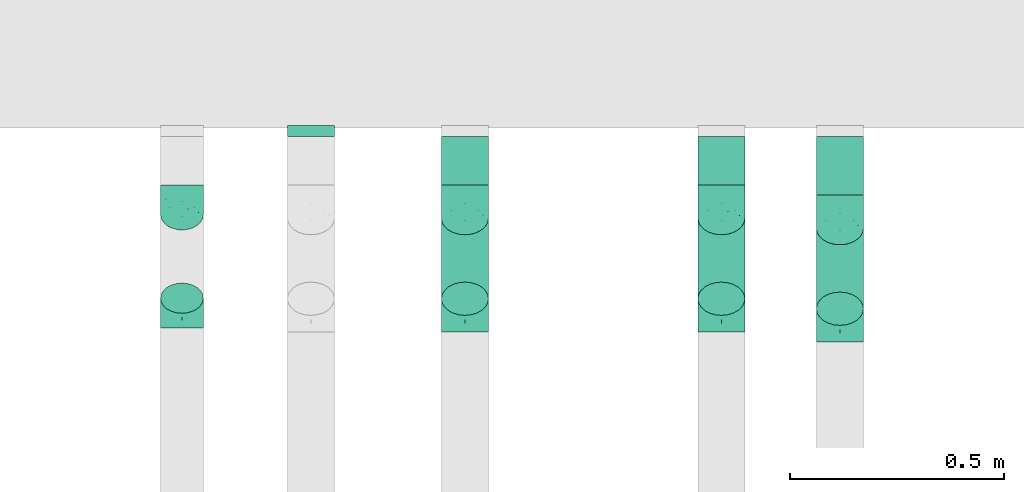
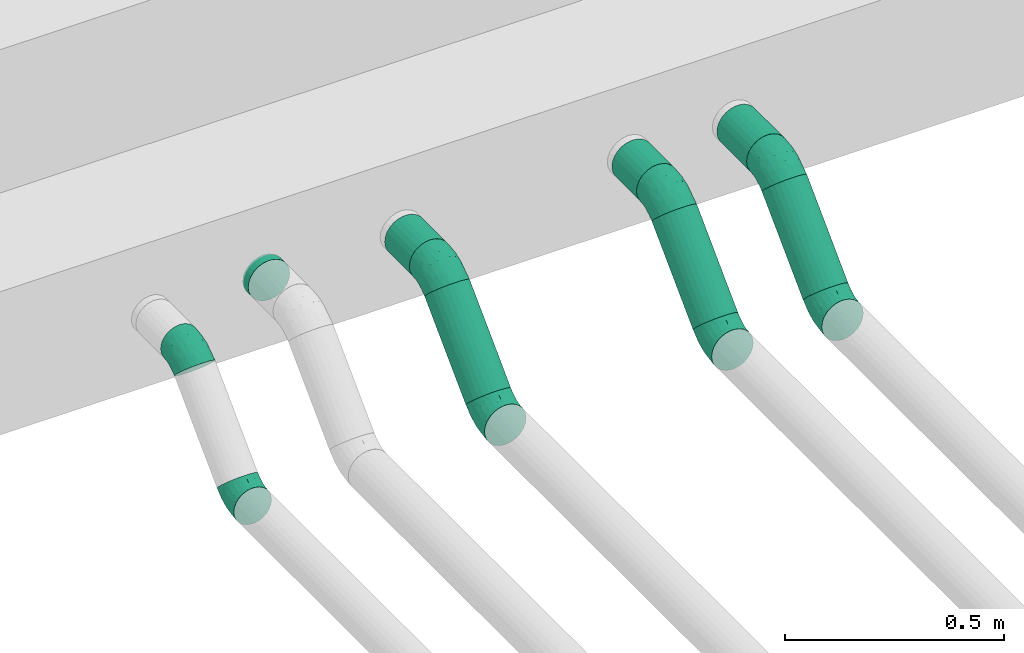
# One storey, part 21 of 91: 9 flow fittings, 6 flow segments.
"""IFC2X3 building model written with IfcOpenShell, lengths in millimetres."""

from ifc_helpers import new_model, entity, si_unit, converted_unit, derived_unit, direction, frame, origin_with_axes, origin_2d_with_axis, place, context, subcontext, project, spatial, hollow_circle, extrude, open_shell, surface_model, source, transform, mapped, material, layer, layer_set, layer_usage, type_object, element, save


model = new_model("IFC2X3")

# Units and contexts
model_context = context("Model", 3, precision=1e-05, world=origin_with_axes(), true_north=direction((0.0, 1.0)))
body_context = subcontext(model_context, "Body", "Model", "MODEL_VIEW")
ifc_project = project(units=[si_unit("AREAUNIT", "SQUARE_METRE"), si_unit("VOLUMEUNIT", "CUBIC_METRE", prefix="DECI"), si_unit("TIMEUNIT", "SECOND"), si_unit("THERMODYNAMICTEMPERATUREUNIT", "DEGREE_CELSIUS"), si_unit("PRESSUREUNIT", "PASCAL"), si_unit("MASSUNIT", "GRAM", prefix="KILO"), si_unit("LENGTHUNIT", "METRE", prefix="MILLI"), si_unit("POWERUNIT", "WATT"), si_unit("ELECTRICCURRENTUNIT", "AMPERE"), si_unit("ELECTRICVOLTAGEUNIT", "VOLT"), derived_unit("VOLUMETRICFLOWRATEUNIT", [(si_unit("VOLUMEUNIT", "CUBIC_METRE", prefix="DECI"), 1), (si_unit("TIMEUNIT", "SECOND"), -1)]), derived_unit("LINEARVELOCITYUNIT", [(si_unit("LENGTHUNIT", "METRE"), 1), (si_unit("TIMEUNIT", "SECOND"), -1)]), derived_unit("MASSDENSITYUNIT", [(si_unit("MASSUNIT", "GRAM", prefix="KILO"), 1), (si_unit("VOLUMEUNIT", "CUBIC_METRE"), -1)]), converted_unit("PLANEANGLEUNIT", "DEGREE", entity("IfcRatioMeasure", 0.01745), si_unit("PLANEANGLEUNIT", "RADIAN"), dimensions=[0, 0, 0, 0, 0, 0, 0])], contexts=[model_context])

# Site, building, storey
site_placement = place(None, origin_with_axes())
site = spatial("IfcSite", under=ifc_project, at=site_placement, CompositionType="ELEMENT")
building_placement = place(site_placement, origin_with_axes())
building = spatial("IfcBuilding", under=site, at=building_placement, Name="mc-building", CompositionType="ELEMENT")
storey_placement = place(building_placement, frame((0.0, 0.0, 8700.0), z_axis=(0.0, 0.0, 1.0), x_axis=(1.0, 0.0, 0.0)))
storey = spatial("IfcBuildingStorey", under=building, at=storey_placement, CompositionType="ELEMENT", Elevation=8700.0)

# Flow segments
ifc_material = material(Name="FZ1")
ifc_layer = layer(ifc_material, 0.0)
ifc_layer_set = layer_set([ifc_layer], Name="FZ1")
ifc_layer_usage = layer_usage(ifc_layer_set, "AXIS1", "POSITIVE", 0.0)
duct_segment_type = type_object("IfcDuctSegmentType", PredefinedType="RIGIDSEGMENT")
shared_shape_1 = source(origin_with_axes(), body_context, "Body", "SweptSolid", [
    extrude(hollow_circle(Radius=55.0, WallThickness=2.0, at=origin_2d_with_axis()), frame((0.0, 0.0, 0.0), z_axis=(1.0, 0.0, 0.0), x_axis=(0.0, 1.0, 0.0)), (0.0, 0.0, 1.0), 266.7),
])
for number, where, z_axis, x_axis in (
    (1, (12930.40917, 2717.07815, 635.78175), (0.0, -0.707107, 0.707107), (0.0, -0.707107, -0.707107)),
    (2, (12653.05388, 2740.42338, 635.78175), (0.0, -0.707107, 0.707107), (0.0, -0.707107, -0.707107)),
    (3, (12053.05418, 2740.42338, 635.78175), (0.0, -0.707107, 0.707107), (0.0, -0.707107, -0.707107)),
):
    element("IfcFlowSegment", number, at=place(storey_placement, frame(where, z_axis=z_axis, x_axis=x_axis)), inside=storey, type_object=duct_segment_type, material=ifc_layer_usage, context=body_context, shape_type="MappedRepresentation", body=[
        mapped(shared_shape_1, transform((0.0, 0.0, 0.0), scale=1.0)),
    ])
shared_shape_2 = source(origin_with_axes(), body_context, "Body", "SweptSolid", [
    extrude(hollow_circle(Radius=55.0, WallThickness=2.0, at=origin_2d_with_axis()), frame((0.0, 0.0, 0.0), z_axis=(1.0, 0.0, 0.0), x_axis=(0.0, 1.0, 0.0)), (0.0, 0.0, 1.0), 136.3),
])
flow_segment_placement = place(storey_placement, frame((12930.40917, 2931.20513, 668.0), z_axis=(0.0, 0.0, 1.0), x_axis=(0.0, -1.0, 0.0)))
element("IfcFlowSegment", 4, at=flow_segment_placement, inside=storey, type_object=duct_segment_type, material=ifc_layer_usage, context=body_context, shape_type="MappedRepresentation", body=[
    mapped(shared_shape_2, transform((0.0, 0.0, 0.0), scale=1.0)),
])

# Flow fittings
duct_fitting_type_1 = type_object("IfcDuctFittingType", Name="BU", PredefinedType="BEND")
shared_shape_3 = source(origin_with_axes(), body_context, "Body", "SurfaceModel", [
    surface_model("IfcShellBasedSurfaceModel", [(-45.56349, 0.0, -55.0), (-45.56349, -14.23505, -53.12592), (-45.56349, 14.23505, -53.12592), (-45.56349, 53.12592, 14.23505), (-45.56349, 27.5, -47.63139), (-45.56349, 38.89087, -38.89087), (-45.56349, 47.63139, -27.5), (-45.56349, -55.0, 0.0), (-45.56349, -53.12592, 14.23505), (-45.56349, -38.89087, -38.89087), (-45.56349, -27.5, -47.63139), (-45.56349, -53.12592, -14.23505), (-45.56349, -47.63139, -27.5), (-45.56349, 53.12592, -14.23505), (-45.56349, 47.63139, 27.5), (-45.56349, 38.89087, 38.89087), (-45.56349, -14.23505, 53.12592), (-45.56349, 27.5, 47.63139), (-45.56349, 14.23505, 53.12592), (-45.56349, -47.63139, 27.5), (-45.56349, -38.89087, 38.89087), (-45.56349, -27.5, 47.63139), (-45.56349, 0.0, 55.0), (-45.56349, 55.0, 0.0), (22.15256, 42.28395, -53.12592), (-6.67262, 71.10913, 0.0), (32.21826, 32.21826, -55.0), (12.77282, 51.66369, -47.63139), (-1.46223, 65.89874, -27.5), (4.71825, 59.71825, -38.89087), (59.71825, 4.71825, -38.89087), (69.78395, -5.34744, 14.23505), (51.66369, 12.77282, -47.63139), (42.28395, 22.15256, -53.12592), (65.89874, -1.46223, -27.5), (69.78395, -5.34744, -14.23505), (71.10913, -6.67262, 0.0), (-5.34744, 69.78395, -14.23505), (-5.34744, 69.78395, 14.23505), (-1.46223, 65.89874, 27.5), (4.71825, 59.71825, 38.89087), (32.21826, 32.21826, 55.0), (12.77282, 51.66369, 47.63139), (22.15256, 42.28395, 53.12592), (59.71825, 4.71825, 38.89087), (65.89874, -1.46223, 27.5), (42.28395, 22.15256, 53.12592), (51.66369, 12.77282, 47.63139), (-20.16649, 48.68621, 33.48188), (-26.97111, 35.77503, 43.63444), (-7.30443, 43.73336, 43.63444), (-17.0934, 3.74816, 55.0), (-18.00408, 15.44793, 53.78143), (-30.11707, 22.39897, 50.81337), (-7.49776, 55.63651, 33.48188), (-15.97018, 58.74288, 21.04759), (-31.18231, 52.58712, 21.04759), (-18.35174, 61.03934, 10.51509), (-28.67677, 56.60048, 10.47121), (-34.03924, 44.64267, 33.48188), (-11.52288, 27.81868, 50.81338), (1.19951, 23.16465, 53.81115), (-33.77926, 57.34403, 0.0), (5.4586, 37.12132, 50.81809), (-24.5159, 59.18663, 0.0), (-16.66281, 64.4339, 0.0), (9.43651, 14.73721, 55.0), (-6.22531, 44.36822, -43.63444), (5.4586, 37.12132, -50.81809), (-34.03924, 44.64267, -33.48188), (9.43651, 14.73721, -55.0), (-17.0934, 3.74816, -55.0), (1.19951, 23.16465, -53.81115), (-11.52288, 27.81868, -50.81338), (-30.11707, 22.39897, -50.81337), (-25.75914, 36.08917, -43.63444), (-30.24487, 52.83011, -21.04759), (-20.16649, 48.68621, -33.48188), (-7.49776, 55.63651, -33.48188), (-18.00408, 15.44793, -53.78143), (-28.68366, 56.62226, -10.35271), (-14.15883, 63.53074, -10.87592), (-15.13548, 59.23394, -21.04759), (3.19797, -7.72059, -52.16847), (3.1272, -18.04126, -47.9241), (13.63233, -32.91136, -32.06475), (45.23618, -22.99734, -20.4997), (16.67434, -40.25541, -15.9539), (-17.3935, -51.68264, -9.80849), (-2.85835, -49.37776, 0.0), (48.84421, -24.24609, -9.80849), (-16.38424, -42.76862, -30.85433), (-6.97383, -29.41689, -42.70541), (41.82739, -18.65658, -30.85433), (-15.72523, -48.24839, -20.4997), (29.28945, -13.63928, -42.80781), (26.81493, -3.56603, -49.15704), (36.93651, -32.89419, 0.0), (-15.72523, -48.24839, 20.4997), (-17.3935, -51.68264, 9.80849), (-16.38424, -42.76862, 30.85433), (16.67434, -40.25541, 15.9539), (3.19797, -7.72059, 52.16847), (10.54583, -14.96836, 47.9241), (13.63233, -32.91136, 32.06475), (45.23618, -22.99734, 20.4997), (41.82739, -18.65658, 30.85433), (-11.06635, -30.3552, 42.80781), (25.73213, -15.86964, 42.70541), (-16.43945, -21.48258, 49.15704), (48.84421, -24.24609, 9.80849)], [open_shell([[[0, 1, 2]], [[2, 3, 4]], [[5, 3, 6]], [[4, 3, 5]], [[2, 7, 8]], [[9, 7, 10]], [[1, 10, 7]], [[11, 7, 12]], [[9, 12, 7]], [[7, 2, 1]], [[13, 6, 3]], [[14, 3, 2]], [[15, 14, 2]], [[16, 17, 2]], [[2, 17, 15]], [[16, 18, 17]], [[19, 20, 2]], [[19, 2, 8]], [[20, 21, 2]], [[2, 21, 16]], [[16, 22, 18]], [[23, 13, 3]], [[24, 25, 26]], [[27, 25, 24]], [[28, 25, 29]], [[29, 25, 27]], [[30, 26, 31]], [[26, 30, 32]], [[32, 33, 26]], [[34, 31, 35]], [[31, 34, 30]], [[35, 31, 36]], [[37, 25, 28]], [[26, 38, 39]], [[26, 39, 40]], [[41, 40, 42]], [[26, 40, 41]], [[42, 43, 41]], [[26, 44, 45]], [[31, 26, 45]], [[46, 47, 26]], [[47, 44, 26]], [[46, 26, 41]], [[26, 25, 38]], [[48, 49, 50]], [[22, 51, 52]], [[17, 49, 15]], [[53, 17, 18]], [[49, 17, 53]], [[54, 50, 40]], [[48, 55, 56]], [[55, 57, 58]], [[59, 14, 15]], [[60, 53, 52]], [[50, 49, 60]], [[58, 3, 56]], [[52, 51, 61]], [[62, 23, 3]], [[63, 50, 60]], [[50, 42, 40]], [[3, 58, 62]], [[43, 61, 41]], [[62, 58, 64]], [[48, 59, 49]], [[14, 56, 3]], [[40, 39, 54]], [[57, 64, 58]], [[39, 38, 55]], [[63, 60, 61]], [[54, 55, 48]], [[65, 57, 38]], [[56, 14, 59]], [[38, 25, 65]], [[60, 52, 61]], [[49, 59, 15]], [[55, 58, 56]], [[56, 59, 48]], [[55, 54, 39]], [[50, 54, 48]], [[18, 22, 52]], [[49, 53, 60]], [[18, 52, 53]], [[61, 51, 66]], [[41, 61, 66]], [[63, 61, 43]], [[43, 42, 63]], [[50, 63, 42]], [[38, 57, 55]], [[64, 57, 65]], [[67, 27, 68]], [[69, 5, 6]], [[70, 71, 72]], [[73, 74, 75]], [[76, 77, 69]], [[29, 78, 28]], [[2, 79, 0]], [[13, 23, 62]], [[2, 74, 79]], [[5, 75, 4]], [[77, 78, 67]], [[13, 62, 80]], [[64, 80, 62]], [[81, 80, 64]], [[67, 73, 75]], [[82, 77, 76]], [[81, 64, 65]], [[76, 69, 6]], [[82, 76, 80]], [[24, 72, 68]], [[74, 2, 4]], [[27, 67, 29]], [[26, 70, 72]], [[69, 75, 5]], [[82, 28, 78]], [[72, 71, 79]], [[6, 13, 76]], [[77, 67, 75]], [[13, 80, 76]], [[82, 37, 28]], [[81, 25, 37]], [[82, 81, 37]], [[75, 69, 77]], [[67, 78, 29]], [[82, 78, 77]], [[75, 74, 4]], [[79, 74, 73]], [[79, 73, 72]], [[79, 71, 0]], [[68, 72, 73]], [[26, 72, 24]], [[67, 68, 73]], [[27, 24, 68]], [[80, 81, 82]], [[25, 81, 65]], [[1, 83, 84]], [[85, 86, 87]], [[0, 71, 1]], [[88, 87, 89]], [[90, 86, 35]], [[91, 92, 85]], [[11, 88, 7]], [[30, 34, 93]], [[11, 12, 94]], [[92, 91, 9]], [[85, 94, 91]], [[94, 85, 87]], [[95, 93, 85]], [[85, 92, 95]], [[83, 71, 70]], [[12, 9, 91]], [[70, 26, 33]], [[96, 84, 83]], [[1, 71, 83]], [[95, 96, 32]], [[95, 30, 93]], [[95, 32, 30]], [[97, 89, 87]], [[34, 86, 93]], [[36, 97, 90]], [[94, 88, 11]], [[34, 35, 86]], [[90, 87, 86]], [[93, 86, 85]], [[32, 96, 33]], [[84, 10, 1]], [[33, 83, 70]], [[94, 12, 91]], [[10, 92, 9]], [[87, 88, 94]], [[7, 88, 89]], [[36, 90, 35]], [[87, 90, 97]], [[84, 95, 92]], [[33, 96, 83]], [[95, 84, 96]], [[10, 84, 92]], [[8, 98, 19]], [[7, 89, 99]], [[19, 98, 100]], [[101, 98, 99]], [[46, 102, 103]], [[104, 105, 106]], [[100, 98, 104]], [[107, 104, 108]], [[16, 51, 22]], [[51, 16, 102]], [[107, 20, 100]], [[107, 109, 21]], [[21, 20, 107]], [[103, 47, 46]], [[101, 89, 97]], [[105, 110, 31]], [[44, 47, 108]], [[105, 104, 101]], [[107, 100, 104]], [[31, 110, 36]], [[109, 16, 21]], [[108, 106, 44]], [[105, 45, 106]], [[41, 66, 46]], [[102, 66, 51]], [[46, 66, 102]], [[104, 98, 101]], [[99, 98, 8]], [[106, 108, 104]], [[110, 101, 97]], [[45, 44, 106]], [[105, 31, 45]], [[20, 19, 100]], [[109, 103, 102]], [[101, 110, 105]], [[36, 110, 97]], [[7, 99, 8]], [[101, 99, 89]], [[103, 107, 108]], [[16, 109, 102]], [[107, 103, 109]], [[47, 103, 108]]])]),
])
for number, where, z_axis, x_axis, name in (
    (5, (12930.40917, 2749.2964, 668.0), (-1.0, 0.0, 0.0), (0.0, 0.707107, 0.707107), "BU"),
    (6, (12930.40917, 2496.2964, 415.0), (1.0, 0.0, 0.0), (0.0, 1.0, 0.0), "BU"),
    (7, (12653.05388, 2772.64164, 668.0), (-1.0, 0.0, 0.0), (0.0, 0.707107, 0.707107), "BU"),
    (8, (12653.05388, 2519.64164, 415.0), (1.0, 0.0, 0.0), (0.0, 1.0, 0.0), "BU"),
    (9, (12053.05418, 2772.64164, 668.0), (-1.0, 0.0, 0.0), (0.0, 0.707107, 0.707107), "BU"),
    (10, (12053.05418, 2519.64164, 415.0), (1.0, 0.0, 0.0), (0.0, 1.0, 0.0), "BU"),
):
    element("IfcFlowFitting", number, at=place(storey_placement, frame(where, z_axis=z_axis, x_axis=x_axis)), inside=storey, type_object=duct_fitting_type_1, Name=name, context=body_context, shape_type="MappedRepresentation", body=[
        mapped(shared_shape_3, transform((0.0, 0.0, 0.0), scale=1.0)),
    ])
duct_fitting_type_2 = type_object("IfcDuctFittingType", Name="CC", PredefinedType="CONNECTOR")
shared_shape_4 = source(origin_with_axes(), body_context, "Body", "SurfaceModel", [
    surface_model("IfcShellBasedSurfaceModel", [(-6.096, -55.0, 0.0), (-6.096, 0.0, -55.0), (-6.096, -14.23505, -53.12592), (-6.096, -27.5, -47.63139), (-6.096, -38.89087, -38.89087), (-6.096, -47.63139, -27.5), (-6.096, 38.89087, -38.89087), (-6.096, 53.12592, 14.23505), (-6.096, 27.5, -47.63139), (-6.096, 14.23505, -53.12592), (-6.096, 47.63139, -27.5), (-6.096, 53.12592, -14.23505), (-6.096, 55.0, 0.0), (-6.096, -53.12592, -14.23505), (-6.096, -53.12592, 14.23505), (-6.096, -47.63139, 27.5), (-6.096, -38.89087, 38.89087), (-6.096, 0.0, 55.0), (-6.096, -27.5, 47.63139), (-6.096, -14.23505, 53.12592), (-6.096, 38.89087, 38.89087), (-6.096, 47.63139, 27.5), (-6.096, 14.23505, 53.12592), (-6.096, 27.5, 47.63139), (0.0, -14.23505, 53.12592), (0.0, 0.0, 55.0), (0.0, -27.5, 47.63139), (0.0, -38.89087, 38.89087), (0.0, -53.12592, 14.23505), (0.0, -47.63139, 27.5), (0.0, -55.0, 0.0), (0.0, -53.12592, -14.23505), (0.0, -47.63139, -27.5), (0.0, -38.89087, -38.89087), (0.0, -14.23505, -53.12592), (0.0, -27.5, -47.63139), (0.0, 0.0, -55.0), (0.0, 14.23505, -53.12592), (0.0, 27.5, -47.63139), (0.0, 38.89087, -38.89087), (0.0, 53.12592, -14.23505), (0.0, 47.63139, -27.5), (0.0, 55.0, 0.0), (0.0, 53.12592, 14.23505), (0.0, 47.63139, 27.5), (0.0, 38.89087, 38.89087), (0.0, 14.23505, 53.12592), (0.0, 27.5, 47.63139), (20.0, 0.0, -55.0), (20.0, 14.23505, -53.12592), (20.0, -14.23505, -53.12592), (20.0, -53.12592, 14.23505), (20.0, -27.5, -47.63139), (20.0, -47.63139, -27.5), (20.0, -38.89087, -38.89087), (20.0, 55.0, 0.0), (20.0, 53.12592, 14.23505), (20.0, 38.89087, -38.89087), (20.0, 27.5, -47.63139), (20.0, 53.12592, -14.23505), (20.0, 47.63139, -27.5), (20.0, -53.12592, -14.23505), (20.0, -47.63139, 27.5), (20.0, -38.89087, 38.89087), (20.0, 14.23505, 53.12592), (20.0, -27.5, 47.63139), (20.0, -14.23505, 53.12592), (20.0, 47.63139, 27.5), (20.0, 38.89087, 38.89087), (20.0, 27.5, 47.63139), (20.0, 0.0, 55.0), (20.0, -55.0, 0.0)], [open_shell([[[0, 1, 2]], [[3, 0, 2]], [[0, 4, 5]], [[4, 0, 3]], [[6, 1, 7]], [[1, 6, 8]], [[8, 9, 1]], [[6, 7, 10]], [[10, 7, 11]], [[12, 11, 7]], [[13, 0, 5]], [[14, 15, 1]], [[1, 15, 16]], [[17, 16, 18]], [[17, 1, 16]], [[19, 17, 18]], [[20, 21, 1]], [[7, 1, 21]], [[22, 23, 1]], [[23, 20, 1]], [[22, 1, 17]], [[0, 14, 1]], [[24, 25, 17]], [[26, 24, 19]], [[19, 24, 17]], [[16, 27, 18]], [[26, 19, 18]], [[26, 18, 27]], [[28, 29, 15]], [[30, 28, 14]], [[15, 29, 16]], [[28, 15, 14]], [[30, 14, 0]], [[27, 16, 29]], [[31, 30, 0]], [[32, 31, 13]], [[13, 31, 0]], [[4, 33, 5]], [[32, 13, 5]], [[32, 5, 33]], [[34, 35, 3]], [[36, 34, 2]], [[3, 35, 4]], [[34, 3, 2]], [[36, 2, 1]], [[33, 4, 35]], [[37, 36, 1]], [[38, 37, 9]], [[9, 37, 1]], [[6, 39, 8]], [[38, 9, 8]], [[38, 8, 39]], [[40, 41, 10]], [[42, 40, 11]], [[10, 41, 6]], [[40, 10, 11]], [[42, 11, 12]], [[39, 6, 41]], [[43, 42, 12]], [[44, 43, 7]], [[7, 43, 12]], [[20, 45, 21]], [[44, 7, 21]], [[44, 21, 45]], [[46, 47, 23]], [[25, 46, 22]], [[23, 47, 20]], [[46, 23, 22]], [[25, 22, 17]], [[45, 20, 47]], [[48, 49, 50]], [[50, 51, 52]], [[53, 54, 51]], [[52, 51, 54]], [[50, 55, 56]], [[57, 55, 58]], [[49, 58, 55]], [[59, 55, 60]], [[57, 60, 55]], [[55, 50, 49]], [[53, 51, 61]], [[50, 62, 51]], [[63, 62, 50]], [[64, 65, 50]], [[65, 63, 50]], [[64, 66, 65]], [[50, 67, 68]], [[67, 50, 56]], [[68, 69, 50]], [[50, 69, 64]], [[64, 70, 66]], [[71, 61, 51]], [[66, 70, 25]], [[65, 66, 24]], [[24, 66, 25]], [[27, 63, 26]], [[65, 24, 26]], [[65, 26, 63]], [[51, 62, 29]], [[71, 51, 28]], [[29, 62, 27]], [[51, 29, 28]], [[71, 28, 30]], [[63, 27, 62]], [[61, 71, 30]], [[53, 61, 31]], [[31, 61, 30]], [[33, 54, 32]], [[53, 31, 32]], [[53, 32, 54]], [[50, 52, 35]], [[48, 50, 34]], [[35, 52, 33]], [[50, 35, 34]], [[48, 34, 36]], [[54, 33, 52]], [[49, 48, 36]], [[58, 49, 37]], [[37, 49, 36]], [[39, 57, 38]], [[58, 37, 38]], [[58, 38, 57]], [[59, 60, 41]], [[55, 59, 40]], [[41, 60, 39]], [[59, 41, 40]], [[55, 40, 42]], [[57, 39, 60]], [[56, 55, 42]], [[67, 56, 43]], [[43, 56, 42]], [[45, 68, 44]], [[67, 43, 44]], [[67, 44, 68]], [[64, 69, 47]], [[70, 64, 46]], [[47, 69, 45]], [[64, 47, 46]], [[70, 46, 25]], [[68, 45, 69]], [[50, 63, 62]], [[50, 64, 65]], [[50, 56, 67]], [[50, 68, 69]], [[64, 50, 69]]])]),
])
flow_fitting_placement = place(storey_placement, frame((11692.81055, 2951.20513, 668.0), z_axis=(0.0, 0.0, -1.0), x_axis=(0.0, -1.0, 0.0)))
element("IfcFlowFitting", 11, at=flow_fitting_placement, inside=storey, type_object=duct_fitting_type_2, Name="CC", context=body_context, shape_type="MappedRepresentation", body=[
    mapped(shared_shape_4, transform((0.0, 0.0, 0.0), scale=1.0)),
])

# Flow segments
shared_shape_5 = source(origin_with_axes(), body_context, "Body", "SweptSolid", [
    extrude(hollow_circle(Radius=55.0, WallThickness=2.0, at=origin_2d_with_axis()), frame((0.0, 0.0, 0.0), z_axis=(1.0, 0.0, 0.0), x_axis=(0.0, 1.0, 0.0)), (0.0, 0.0, 1.0), 113.0),
])
for number, where, z_axis, x_axis in (
    (12, (12653.05388, 2931.20513, 668.0), (0.0, 0.0, 1.0), (0.0, -1.0, 0.0)),
    (13, (12053.05418, 2931.20513, 668.0), (0.0, 0.0, 1.0), (0.0, -1.0, 0.0)),
):
    element("IfcFlowSegment", number, at=place(storey_placement, frame(where, z_axis=z_axis, x_axis=x_axis)), inside=storey, type_object=duct_segment_type, material=ifc_layer_usage, context=body_context, shape_type="MappedRepresentation", body=[
        mapped(shared_shape_5, transform((0.0, 0.0, 0.0), scale=1.0)),
    ])

# Flow fittings
shared_shape_6 = source(origin_with_axes(), body_context, "Body", "SurfaceModel", [
    surface_model("IfcShellBasedSurfaceModel", [(-41.0, 0.0, -50.0), (-41.0, -12.94095, -48.29629), (-41.0, 12.94095, -48.29629), (-41.0, 48.29629, 12.94095), (-41.0, 25.0, -43.30127), (-41.0, 43.30127, -25.0), (-41.0, 35.35534, -35.35534), (-41.0, -50.0, 0.0), (-41.0, -48.29629, 12.94095), (-41.0, -35.35534, -35.35534), (-41.0, -25.0, -43.30127), (-41.0, -48.29629, -12.94095), (-41.0, -43.30127, -25.0), (-41.0, 48.29629, -12.94095), (-41.0, 43.30127, 25.0), (-41.0, 35.35534, 35.35534), (-41.0, -12.94095, 48.29629), (-41.0, 25.0, 43.30127), (-41.0, 12.94095, 48.29629), (-41.0, -43.30127, 25.0), (-41.0, -35.35534, 35.35534), (-41.0, -25.0, 43.30127), (-41.0, 0.0, 50.0), (-41.0, 50.0, 0.0), (19.84074, 38.14201, -48.29629), (-6.36396, 64.34672, 0.0), (28.99138, 28.99138, -50.0), (11.31371, 46.66905, -43.30127), (3.99138, 53.99138, -35.35534), (-1.62724, 59.61, -25.0), (53.99138, 3.99138, -35.35534), (63.14201, -5.15926, 12.94095), (46.66905, 11.31371, -43.30127), (38.14201, 19.84074, -48.29629), (59.61, -1.62724, -25.0), (63.14201, -5.15926, -12.94095), (64.34672, -6.36396, 0.0), (-5.15926, 63.14201, -12.94095), (-5.15926, 63.14201, 12.94095), (-1.62724, 59.61, 25.0), (3.99138, 53.99138, 35.35534), (28.99138, 28.99138, 50.0), (11.31371, 46.66905, 43.30127), (19.84074, 38.14201, 48.29629), (59.61, -1.62724, 25.0), (53.99138, 3.99138, 35.35534), (38.14201, 19.84074, 48.29629), (46.66905, 11.31371, 43.30127), (-18.30109, 44.18276, 30.43807), (-24.345, 32.49227, 39.66767), (-6.72766, 39.62131, 39.66767), (-15.38138, 3.37276, 50.0), (-16.23064, 14.00293, 48.89221), (-27.13444, 20.34725, 46.19398), (-6.97826, 50.39468, 30.43807), (-14.60561, 53.26633, 19.13417), (-28.17337, 47.77599, 19.13417), (-16.73188, 55.37236, 9.57436), (-25.91257, 51.41785, 9.5354), (-30.70005, 40.56879, 30.43807), (-10.44327, 25.21228, 46.19398), (1.0295, 20.93716, 48.91923), (-30.42146, 52.10421, 0.0), (4.80032, 33.56273, 46.19826), (-22.25511, 53.72859, 0.0), (-15.33202, 58.35446, 0.0), (8.49138, 13.26118, 50.0), (-5.76099, 40.19002, -39.66767), (4.80032, 33.56273, -46.19826), (-30.70005, 40.56879, -30.43807), (8.49138, 13.26118, -50.0), (-15.38138, 3.37276, -50.0), (1.0295, 20.93716, -48.91923), (-10.44327, 25.21228, -46.19398), (-27.13444, 20.34725, -46.19398), (-23.25933, 32.77367, -39.66767), (-27.33726, 47.99271, -19.13417), (-18.30109, 44.18276, -30.43807), (-6.97826, 50.39468, -30.43807), (-16.23064, 14.00293, -48.89221), (-25.91896, 51.438, -9.42588), (-13.02367, 57.57988, -9.8805), (-13.86114, 53.70431, -19.13417), (2.93034, -7.07447, -47.43371), (2.81434, -16.4825, -43.57717), (12.42788, -30.00357, -29.13965), (40.96913, -21.08746, -18.63201), (15.19143, -36.67536, -14.49606), (-15.58185, -47.0029, -8.91278), (-2.44043, -44.92353, 0.0), (44.2541, -22.21804, -8.91278), (-14.66706, -38.90004, -28.04813), (-6.17907, -26.78474, -38.81666), (37.87766, -17.1353, -28.04813), (-14.05847, -43.88064, -18.63201), (26.52839, -12.54993, -38.91078), (24.22802, -3.41873, -44.68725), (33.49138, -30.04009, 0.0), (-14.05847, -43.88064, 18.63201), (-15.58185, -47.0029, 8.91278), (-14.66706, -38.90004, 28.04813), (15.19143, -36.67536, 14.49606), (2.93034, -7.07447, 47.43371), (9.66485, -13.64492, 43.57717), (12.42788, -30.00357, 29.13965), (40.96913, -21.08746, 18.63201), (37.87766, -17.1353, 28.04813), (-9.88426, -27.63255, 38.91078), (23.30894, -14.57041, 38.81666), (-14.71439, -19.5492, 44.68725), (44.2541, -22.21804, 8.91278)], [open_shell([[[0, 1, 2]], [[2, 3, 4]], [[5, 6, 3]], [[3, 6, 4]], [[2, 7, 8]], [[9, 7, 10]], [[1, 10, 7]], [[11, 7, 12]], [[9, 12, 7]], [[7, 2, 1]], [[13, 5, 3]], [[14, 3, 2]], [[15, 14, 2]], [[16, 17, 2]], [[15, 2, 17]], [[18, 17, 16]], [[8, 19, 2]], [[2, 19, 20]], [[2, 20, 21]], [[16, 2, 21]], [[16, 22, 18]], [[23, 13, 3]], [[24, 25, 26]], [[27, 25, 24]], [[25, 28, 29]], [[27, 28, 25]], [[30, 26, 31]], [[26, 30, 32]], [[32, 33, 26]], [[34, 31, 35]], [[34, 30, 31]], [[36, 35, 31]], [[37, 25, 29]], [[26, 38, 39]], [[26, 39, 40]], [[41, 40, 42]], [[40, 41, 26]], [[41, 42, 43]], [[44, 31, 26]], [[45, 44, 26]], [[46, 47, 26]], [[45, 26, 47]], [[26, 41, 46]], [[25, 38, 26]], [[48, 49, 50]], [[22, 51, 52]], [[17, 49, 15]], [[53, 17, 18]], [[49, 17, 53]], [[54, 50, 40]], [[48, 55, 56]], [[55, 57, 58]], [[59, 14, 15]], [[60, 53, 52]], [[50, 49, 60]], [[58, 3, 56]], [[52, 51, 61]], [[62, 23, 3]], [[63, 50, 60]], [[50, 42, 40]], [[3, 58, 62]], [[43, 61, 41]], [[62, 58, 64]], [[48, 59, 49]], [[14, 56, 3]], [[40, 39, 54]], [[57, 64, 58]], [[39, 38, 55]], [[63, 60, 61]], [[54, 55, 48]], [[65, 57, 38]], [[56, 14, 59]], [[38, 25, 65]], [[60, 52, 61]], [[49, 59, 15]], [[55, 58, 56]], [[56, 59, 48]], [[55, 54, 39]], [[50, 54, 48]], [[18, 22, 52]], [[49, 53, 60]], [[18, 52, 53]], [[61, 51, 66]], [[41, 61, 66]], [[63, 61, 43]], [[43, 42, 63]], [[50, 63, 42]], [[38, 57, 55]], [[64, 57, 65]], [[67, 27, 68]], [[69, 6, 5]], [[70, 71, 72]], [[73, 74, 75]], [[76, 77, 69]], [[28, 78, 29]], [[2, 79, 0]], [[13, 23, 62]], [[2, 74, 79]], [[6, 75, 4]], [[77, 78, 67]], [[13, 62, 80]], [[64, 80, 62]], [[81, 80, 64]], [[67, 73, 75]], [[82, 77, 76]], [[81, 64, 65]], [[76, 69, 5]], [[82, 76, 80]], [[24, 72, 68]], [[74, 2, 4]], [[27, 67, 28]], [[26, 70, 72]], [[69, 75, 6]], [[82, 29, 78]], [[72, 71, 79]], [[5, 13, 76]], [[77, 67, 75]], [[13, 80, 76]], [[82, 37, 29]], [[81, 25, 37]], [[82, 81, 37]], [[75, 69, 77]], [[67, 78, 28]], [[82, 78, 77]], [[75, 74, 4]], [[79, 74, 73]], [[79, 73, 72]], [[79, 71, 0]], [[68, 72, 73]], [[26, 72, 24]], [[67, 68, 73]], [[27, 24, 68]], [[80, 81, 82]], [[25, 81, 65]], [[1, 83, 84]], [[85, 86, 87]], [[0, 71, 1]], [[88, 87, 89]], [[90, 86, 35]], [[91, 92, 85]], [[11, 88, 7]], [[30, 34, 93]], [[11, 12, 94]], [[92, 91, 9]], [[85, 94, 91]], [[94, 85, 87]], [[95, 93, 85]], [[85, 92, 95]], [[83, 71, 70]], [[12, 9, 91]], [[70, 26, 33]], [[96, 84, 83]], [[1, 71, 83]], [[95, 96, 32]], [[95, 30, 93]], [[95, 32, 30]], [[97, 89, 87]], [[34, 86, 93]], [[36, 97, 90]], [[94, 88, 11]], [[34, 35, 86]], [[90, 87, 86]], [[93, 86, 85]], [[32, 96, 33]], [[84, 10, 1]], [[33, 83, 70]], [[94, 12, 91]], [[10, 92, 9]], [[87, 88, 94]], [[7, 88, 89]], [[36, 90, 35]], [[87, 90, 97]], [[84, 95, 92]], [[33, 96, 83]], [[95, 84, 96]], [[10, 84, 92]], [[8, 98, 19]], [[7, 89, 99]], [[19, 98, 100]], [[101, 98, 99]], [[46, 102, 103]], [[104, 105, 106]], [[100, 98, 104]], [[107, 104, 108]], [[16, 51, 22]], [[51, 16, 102]], [[107, 20, 100]], [[107, 109, 21]], [[21, 20, 107]], [[103, 47, 46]], [[101, 89, 97]], [[105, 110, 31]], [[45, 47, 108]], [[105, 104, 101]], [[107, 100, 104]], [[31, 110, 36]], [[109, 16, 21]], [[108, 106, 45]], [[105, 44, 106]], [[41, 66, 46]], [[102, 66, 51]], [[46, 66, 102]], [[104, 98, 101]], [[99, 98, 8]], [[106, 108, 104]], [[110, 101, 97]], [[44, 45, 106]], [[105, 31, 44]], [[20, 19, 100]], [[109, 103, 102]], [[101, 110, 105]], [[36, 110, 97]], [[7, 99, 8]], [[101, 99, 89]], [[103, 107, 108]], [[16, 109, 102]], [[107, 103, 109]], [[47, 103, 108]]])]),
])
for number, where, z_axis, x_axis, name in (
    (14, (11390.97051, 2777.20513, 668.0), (-1.0, 0.0, 0.0), (0.0, 0.707107, 0.707107), "BU"),
    (15, (11390.97051, 2524.20513, 415.0), (1.0, 0.0, 0.0), (0.0, 1.0, 0.0), "BU"),
):
    element("IfcFlowFitting", number, at=place(storey_placement, frame(where, z_axis=z_axis, x_axis=x_axis)), inside=storey, type_object=duct_fitting_type_1, Name=name, context=body_context, shape_type="MappedRepresentation", body=[
        mapped(shared_shape_6, transform((0.0, 0.0, 0.0), scale=1.0)),
    ])

save(model, "model.ifc")
